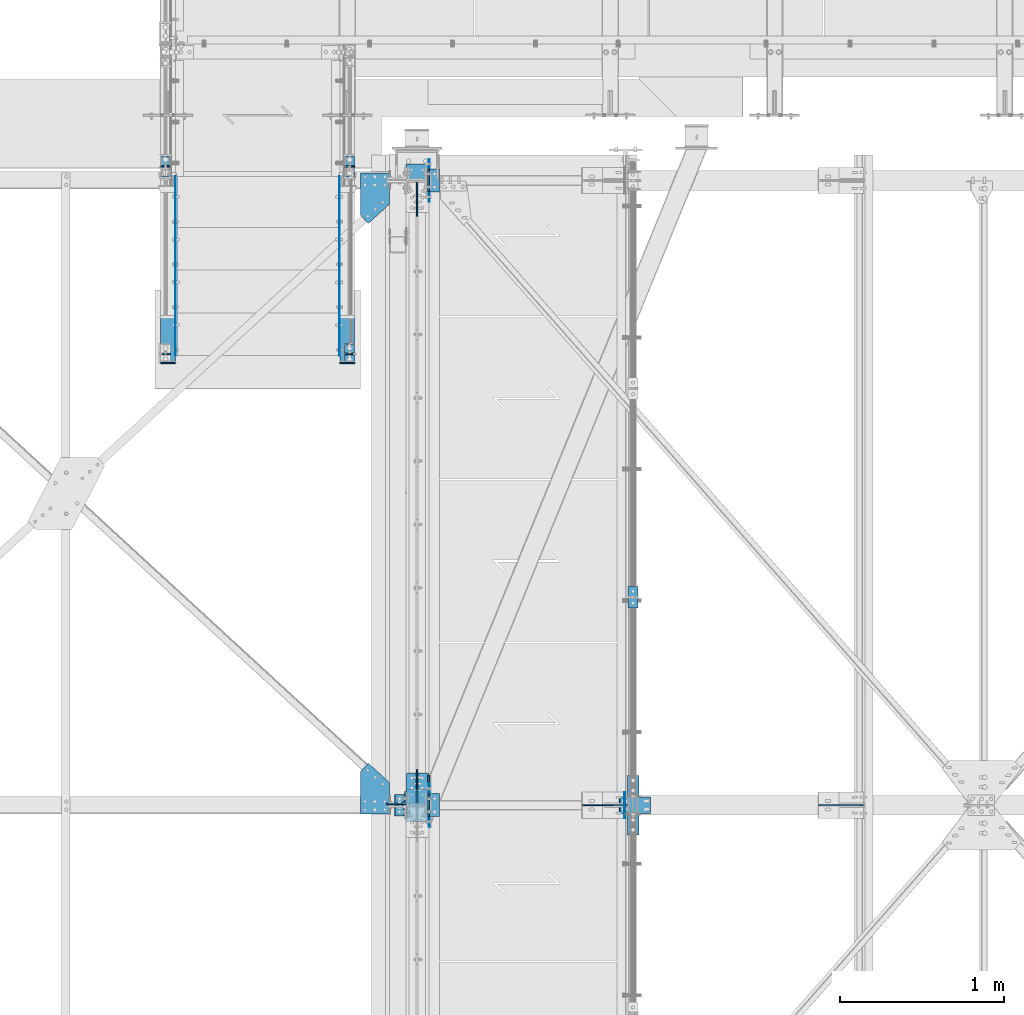
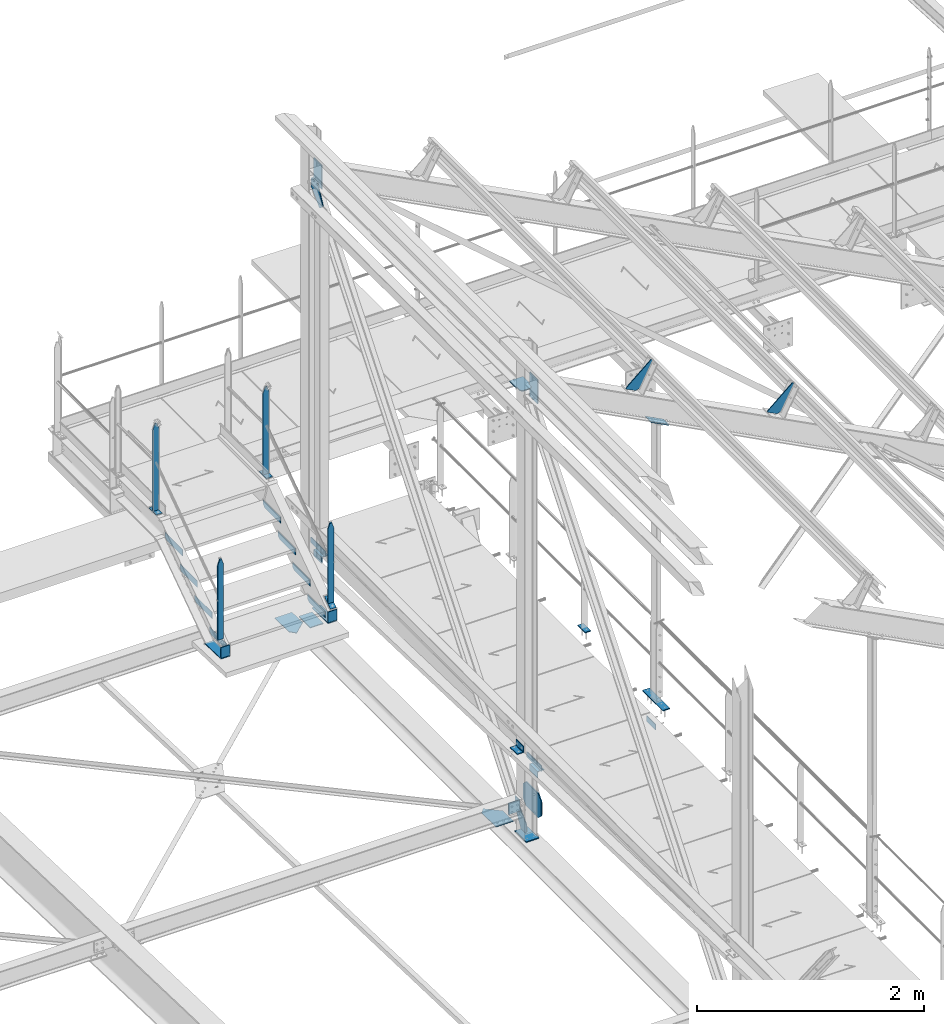
# One storey, part 82 of 496: 38 beams, 3 members, 25 elements without a shape of their own.
"""IFC2X3 building model written with IfcOpenShell, lengths in millimetres."""

from ifc_helpers import new_model, si_unit, frame, frame_2d, origin_with_axes, origin_2d_with_axis, place, context, subcontext, project, spatial, polyline, circle_curve, parameter, trimmed, segment, composite_curve, rectangle, l_section, outline, extrude, clip, halfspace, material, type_object, element, aggregate, save


model = new_model("IFC2X3")

# Units and contexts
model_context = context("Model", 3, precision=1e-05, world=origin_with_axes())
body_context = subcontext(model_context, "Body", "Model", "MODEL_VIEW")
ifc_project = project(units=[si_unit("LENGTHUNIT", "METRE", prefix="MILLI"), si_unit("AREAUNIT", "SQUARE_METRE"), si_unit("VOLUMEUNIT", "CUBIC_METRE"), si_unit("MASSUNIT", "GRAM", prefix="KILO"), si_unit("TIMEUNIT", "SECOND"), si_unit("PLANEANGLEUNIT", "RADIAN"), si_unit("SOLIDANGLEUNIT", "STERADIAN"), si_unit("THERMODYNAMICTEMPERATUREUNIT", "DEGREE_CELSIUS"), si_unit("LUMINOUSINTENSITYUNIT", "LUMEN")], contexts=[model_context])

# Site, building, storey
site_placement = place(None, origin_with_axes())
site = spatial("IfcSite", under=ifc_project, at=site_placement, CompositionType="ELEMENT")
building_placement = place(site_placement, origin_with_axes())
building = spatial("IfcBuilding", under=site, at=building_placement, Name="Undefined", CompositionType="ELEMENT")
storey_placement = place(building_placement, origin_with_axes())
storey = spatial("IfcBuildingStorey", under=building, at=storey_placement, Name="Undefined", CompositionType="ELEMENT", Elevation=0.0)

# Assembly, beams
assembly_1_placement = place(storey_placement, origin_with_axes())
assembly_1 = element("IfcElementAssembly", 1, at=assembly_1_placement, inside=storey, Name="MAIN COURANTE", AssemblyPlace="NOTDEFINED", PredefinedType="NOTDEFINED")
ifc_material = material(Name="Undefined/S235-E24")
beam_type_1 = type_object("IfcBeamType", PredefinedType="NOTDEFINED")
beam_1_placement = place(assembly_1_placement, frame((12269.9936634988, 15350.0038033311, 8915.0), z_axis=(1.0, 0.0, 0.0), x_axis=(0.0, -1.0, 0.0)))
beam_1 = element("IfcBeam", 2, at=beam_1_placement, type_object=beam_type_1, material=ifc_material, context=body_context, shape_type="SweptSolid", body=[
    extrude(rectangle(XDim=10.0, YDim=60.0, at=origin_2d_with_axis()), frame((130.0, 0.0, 0.0), z_axis=(-1.0, 0.0, 0.0), x_axis=(0.0, -1.0, 0.0)), (0.0, 0.0, 1.0), 130.0),
])
beam_2_placement = place(assembly_1_placement, frame((12269.9937887991, 15285.0038033311, 9857.59999847), z_axis=(0.999999999998558, -1.69800000185205e-06, 0.0), x_axis=(0.0, 0.0, -1.0)))
beam_2 = element("IfcBeam", 3, at=beam_2_placement, type_object=beam_type_1, material=ifc_material, Name="MONTANT", context=body_context, shape_type="Clipping", body=[
    clip(clip(extrude(rectangle(XDim=10.0, YDim=60.0, at=origin_2d_with_axis()), frame((937.599998469999, 0.0, 0.0), z_axis=(-1.0, 0.0, 0.0), x_axis=(0.0, -1.0, 0.0)), (0.0, 0.0, 1.0), 937.6), halfspace(frame((-119.999937359999, 4.99999999999818, -30.0), z_axis=(-0.316227766016843, 1.98085072621335e-06, 0.948683298048444), x_axis=(0.948683298050514, 0.0, 0.316227766016838)), False)), halfspace(frame((60.0, 5.0, -30.0), z_axis=(-0.316227469016822, -1.98084886580522e-06, -0.948683397048399), x_axis=(-0.948683298050514, 0.0, 0.316227766016838)), False)),
])

assembly_2_placement = place(storey_placement, origin_with_axes())
assembly_2 = element("IfcElementAssembly", 4, at=assembly_2_placement, inside=storey, Name="MAIN COURANTE", AssemblyPlace="NOTDEFINED", PredefinedType="NOTDEFINED")
beam_3_placement = place(assembly_2_placement, frame((11149.9863365012, 15350.0038033311, 8915.0), z_axis=(-1.0, 0.0, 0.0), x_axis=(0.0, -1.0, 0.0)))
beam_3 = element("IfcBeam", 5, at=beam_3_placement, type_object=beam_type_1, material=ifc_material, context=body_context, shape_type="SweptSolid", body=[
    extrude(rectangle(XDim=10.0, YDim=60.0, at=origin_2d_with_axis()), frame((130.0, 0.0, 0.0), z_axis=(-1.0, 0.0, 0.0), x_axis=(0.0, -1.0, 0.0)), (0.0, 0.0, 1.0), 130.0),
])
beam_4_placement = place(assembly_2_placement, frame((11149.9862112009, 15285.0038033311, 9857.59999847), z_axis=(-0.99999999999782, -2.08799998896818e-06, 0.0), x_axis=(0.0, 0.0, -1.0)))
beam_4 = element("IfcBeam", 6, at=beam_4_placement, type_object=beam_type_1, material=ifc_material, Name="MONTANT", context=body_context, shape_type="Clipping", body=[
    clip(clip(extrude(rectangle(XDim=10.0, YDim=60.0, at=origin_2d_with_axis()), frame((937.599998469999, 0.0, 0.0), z_axis=(-1.0, 0.0, 0.0), x_axis=(0.0, -1.0, 0.0)), (0.0, 0.0, 1.0), 937.6), halfspace(frame((-119.999937359999, -4.99999999999636, -30.0), z_axis=(-0.316227766016837, -1.98085072276202e-06, 0.948683298048446), x_axis=(-6.26399999950979e-06, 0.999999999980381, -3.63797880701241e-15)), False)), halfspace(frame((60.0, -5.0, -30.0), z_axis=(-0.316227469016822, 1.98084886235393e-06, -0.948683397048399), x_axis=(6.26399999950979e-06, 0.999999999980381, -3.63797880701241e-15)), False)),
])
beam_5_placement = place(assembly_2_placement, frame((11149.9862112009, 14144.9998536997, 9085.35366746007), z_axis=(-0.99999999999782, -2.08799998896818e-06, 0.0), x_axis=(0.0, 0.0, -1.0)))
beam_5 = element("IfcBeam", 7, at=beam_5_placement, type_object=beam_type_1, material=ifc_material, Name="MONTANT", context=body_context, shape_type="Clipping", body=[
    clip(clip(clip(clip(extrude(rectangle(XDim=10.0, YDim=60.0, at=origin_2d_with_axis()), frame((863.260305025577, 0.0, 0.0), z_axis=(-1.0, 0.0, 0.0), x_axis=(0.0, -1.0, 0.0)), (0.0, 0.0, 1.0), 870.25), halfspace(frame((-119.999937359999, -4.99999999999636, -30.0), z_axis=(-0.316227766016837, -1.98085072276202e-06, 0.948683298048446), x_axis=(-6.26399999950979e-06, 0.999999999980381, -3.63797880701241e-15)), False)), halfspace(frame((60.0, -5.0, -30.0), z_axis=(-0.316227469016822, 1.98084886235393e-06, -0.948683397048399), x_axis=(6.26399999950979e-06, 0.999999999980381, -3.63797880701241e-15)), False)), halfspace(frame((851.815615457686, -6.43113634479596, -0.000138728501042351), z_axis=(0.822192191679509, -0.569209978778308, -6.66011673277761e-07), x_axis=(0.569209978778308, 0.822192191677987, 1.71673729643302e-06)), False)), halfspace(frame((-7.87605918300687, -11.3765299322586, -0.000149054481880739), z_axis=(0.822192191679509, -0.569209978778308, -6.66011673277761e-07), x_axis=(0.569209978778308, 0.822192191677987, 1.71673729643302e-06)), True)),
])
aggregate(assembly_2, [beam_3, beam_4, beam_5])

# Beam
beam_6_placement = place(assembly_1_placement, frame((12269.9937887991, 14144.9998536997, 9085.35366746007), z_axis=(0.999999999998558, -1.69800000185205e-06, 0.0), x_axis=(0.0, 0.0, -1.0)))
beam_6 = element("IfcBeam", 8, at=beam_6_placement, type_object=beam_type_1, material=ifc_material, Name="MONTANT", context=body_context, shape_type="Clipping", body=[
    clip(clip(clip(clip(extrude(rectangle(XDim=10.0, YDim=60.0, at=origin_2d_with_axis()), frame((863.260305025577, 0.0, 0.0), z_axis=(-1.0, 0.0, 0.0), x_axis=(0.0, -1.0, 0.0)), (0.0, 0.0, 1.0), 870.25), halfspace(frame((-119.999937359999, 4.99999999999818, -30.0), z_axis=(-0.316227766016843, 1.98085072621335e-06, 0.948683298048444), x_axis=(0.948683298050514, 0.0, 0.316227766016838)), False)), halfspace(frame((60.0, 5.0, -30.0), z_axis=(-0.316227469016822, -1.98084886580522e-06, -0.948683397048399), x_axis=(-0.948683298050514, 0.0, 0.316227766016838)), False)), halfspace(frame((851.815615457686, 6.43113634479596, -0.000138728501042351), z_axis=(0.822192191679509, 0.569209978778308, -6.6601167379545e-07), x_axis=(0.0, -2.08799999927579e-06, -0.99999999999782)), False)), halfspace(frame((-7.87605918300687, 11.3765299322586, -0.000149054481880739), z_axis=(0.822192191679509, 0.569209978778308, -6.6601167379545e-07), x_axis=(0.0, -2.08799999927579e-06, -0.99999999999782)), True)),
])

# Assembly, beam
assembly_3_placement = place(storey_placement, origin_with_axes())
assembly_3 = element("IfcElementAssembly", 9, at=assembly_3_placement, inside=storey, Name="MAIN COURANTE", AssemblyPlace="NOTDEFINED", PredefinedType="NOTDEFINED")
beam_7_placement = place(assembly_3_placement, frame((13993.9998916707, 12730.0034471735, 8245.00000008426), z_axis=(-1.0, 0.0, 0.0), x_axis=(0.0, -1.0, 0.0)))
beam_7 = element("IfcBeam", 10, at=beam_7_placement, type_object=beam_type_1, material=ifc_material, context=body_context, shape_type="SweptSolid", body=[
    extrude(rectangle(XDim=10.0, YDim=60.0, at=origin_2d_with_axis()), frame((130.0, 0.0, 0.0), z_axis=(-1.0, 0.0, 0.0), x_axis=(0.0, -1.0, 0.0)), (0.0, 0.0, 1.0), 130.0),
])
aggregate(assembly_3, [beam_7])

# Member
member_type_1 = type_object("IfcMemberType", PredefinedType="NOTDEFINED")
member_1_placement = place(assembly_1_placement, frame((12269.9936634988, 14205.3993570111, 8264.81946439709), z_axis=(1.0, 0.0, 0.0), x_axis=(8.10000000154612e-07, -0.822192191679509, -0.569209978778122)))
member_1 = element("IfcMember", 11, at=member_1_placement, type_object=member_type_1, material=ifc_material, context=body_context, shape_type="SweptSolid", body=[
    extrude(rectangle(XDim=10.0, YDim=60.0, at=origin_2d_with_axis()), frame((130.0, 0.0, 0.0), z_axis=(-1.0, 0.0, 0.0), x_axis=(0.0, -1.0, 0.0)), (0.0, 0.0, 1.0), 130.0),
])

aggregate(assembly_1, [beam_1, beam_2, member_1, beam_6])

# Assembly, beams
assembly_4_placement = place(storey_placement, origin_with_axes())
assembly_4 = element("IfcElementAssembly", 12, at=assembly_4_placement, inside=storey, Name="MARCHE", AssemblyPlace="NOTDEFINED", PredefinedType="NOTDEFINED")
beam_type_2 = type_object("IfcBeamType", PredefinedType="NOTDEFINED")
beam_8_placement = place(assembly_4_placement, frame((11211.4947340707, 15224.9997910501, 8700.0), z_axis=(-1.0, 0.0, 0.0), x_axis=(0.0, 0.0, -1.0)))
beam_8 = element("IfcBeam", 13, at=beam_8_placement, type_object=beam_type_2, material=ifc_material, Name="PLAT MARCHE", context=body_context, shape_type="SweptSolid", body=[
    extrude(outline(polyline([(0.0, 0.0), (50.0, 0.0), (70.0, 30.0), (70.0, 310.0), (0.0, 310.0), (0.0, 0.0)])), frame((0.0, 0.0, -1.5), z_axis=(0.0, 0.0, 1.0), x_axis=(1.0, 0.0, 0.0)), (0.0, 0.0, 1.0), 3.0),
])
beam_9_placement = place(assembly_4_placement, frame((12208.4947340707, 15224.9997910501, 8700.0), z_axis=(-1.0, 0.0, 0.0), x_axis=(0.0, 0.0, -1.0)))
beam_9 = element("IfcBeam", 14, at=beam_9_placement, type_object=beam_type_2, material=ifc_material, Name="PLAT MARCHE", context=body_context, shape_type="SweptSolid", body=[
    extrude(outline(polyline([(0.0, 0.0), (50.0, 0.0), (70.0, 30.0), (70.0, 310.0), (0.0, 310.0), (0.0, 0.0)])), frame((0.0, 0.0, -1.5), z_axis=(0.0, 0.0, 1.0), x_axis=(1.0, 0.0, 0.0)), (0.0, 0.0, 1.0), 3.0),
])
aggregate(assembly_4, [beam_8, beam_9])

assembly_5_placement = place(storey_placement, origin_with_axes())
assembly_5 = element("IfcElementAssembly", 15, at=assembly_5_placement, inside=storey, Name="MARCHE", AssemblyPlace="NOTDEFINED", PredefinedType="NOTDEFINED")
beam_10_placement = place(assembly_5_placement, frame((11211.4947340707, 14964.9997910501, 8520.00000004865), z_axis=(-1.0, 0.0, 0.0), x_axis=(0.0, 0.0, -1.0)))
beam_10 = element("IfcBeam", 16, at=beam_10_placement, type_object=beam_type_2, material=ifc_material, Name="PLAT MARCHE", context=body_context, shape_type="SweptSolid", body=[
    extrude(outline(polyline([(0.0, 0.0), (50.0, 0.0), (70.0, 30.0), (70.0, 310.0), (0.0, 310.0), (0.0, 0.0)])), frame((0.0, 0.0, -1.5), z_axis=(0.0, 0.0, 1.0), x_axis=(1.0, 0.0, 0.0)), (0.0, 0.0, 1.0), 3.0),
])
beam_11_placement = place(assembly_5_placement, frame((12208.4947340707, 14964.9997910501, 8520.00000004865), z_axis=(-1.0, 0.0, 0.0), x_axis=(0.0, 0.0, -1.0)))
beam_11 = element("IfcBeam", 17, at=beam_11_placement, type_object=beam_type_2, material=ifc_material, Name="PLAT MARCHE", context=body_context, shape_type="SweptSolid", body=[
    extrude(outline(polyline([(0.0, 0.0), (50.0, 0.0), (70.0, 30.0), (70.0, 310.0), (0.0, 310.0), (0.0, 0.0)])), frame((0.0, 0.0, -1.5), z_axis=(0.0, 0.0, 1.0), x_axis=(1.0, 0.0, 0.0)), (0.0, 0.0, 1.0), 3.0),
])
aggregate(assembly_5, [beam_10, beam_11])

assembly_6_placement = place(storey_placement, origin_with_axes())
assembly_6 = element("IfcElementAssembly", 18, at=assembly_6_placement, inside=storey, Name="MARCHE", AssemblyPlace="NOTDEFINED", PredefinedType="NOTDEFINED")
beam_12_placement = place(assembly_6_placement, frame((11211.4947340707, 14704.9997910501, 8340.00000007297), z_axis=(-1.0, 0.0, 0.0), x_axis=(0.0, 0.0, -1.0)))
beam_12 = element("IfcBeam", 19, at=beam_12_placement, type_object=beam_type_2, material=ifc_material, Name="PLAT MARCHE", context=body_context, shape_type="SweptSolid", body=[
    extrude(outline(polyline([(0.0, 0.0), (50.0, 0.0), (70.0, 30.0), (70.0, 310.0), (0.0, 310.0), (0.0, 0.0)])), frame((0.0, 0.0, -1.5), z_axis=(0.0, 0.0, 1.0), x_axis=(1.0, 0.0, 0.0)), (0.0, 0.0, 1.0), 3.0),
])
beam_13_placement = place(assembly_6_placement, frame((12208.4947340707, 14704.9997910501, 8340.00000007297), z_axis=(-1.0, 0.0, 0.0), x_axis=(0.0, 0.0, -1.0)))
beam_13 = element("IfcBeam", 20, at=beam_13_placement, type_object=beam_type_2, material=ifc_material, Name="PLAT MARCHE", context=body_context, shape_type="SweptSolid", body=[
    extrude(outline(polyline([(0.0, 0.0), (50.0, 0.0), (70.0, 30.0), (70.0, 310.0), (0.0, 310.0), (0.0, 0.0)])), frame((0.0, 0.0, -1.5), z_axis=(0.0, 0.0, 1.0), x_axis=(1.0, 0.0, 0.0)), (0.0, 0.0, 1.0), 3.0),
])
aggregate(assembly_6, [beam_12, beam_13])

assembly_7_placement = place(storey_placement, origin_with_axes())
assembly_7 = element("IfcElementAssembly", 21, at=assembly_7_placement, inside=storey, Name="MARCHE", AssemblyPlace="NOTDEFINED", PredefinedType="NOTDEFINED")
beam_14_placement = place(assembly_7_placement, frame((11211.4947340707, 14444.9997910501, 8160.0000000973), z_axis=(-1.0, 0.0, 0.0), x_axis=(0.0, 0.0, -1.0)))
beam_14 = element("IfcBeam", 22, at=beam_14_placement, type_object=beam_type_2, material=ifc_material, Name="PLAT MARCHE", context=body_context, shape_type="SweptSolid", body=[
    extrude(outline(polyline([(0.0, 0.0), (50.0, 0.0), (70.0, 30.0), (70.0, 310.0), (0.0, 310.0), (0.0, 0.0)])), frame((0.0, 0.0, -1.5), z_axis=(0.0, 0.0, 1.0), x_axis=(1.0, 0.0, 0.0)), (0.0, 0.0, 1.0), 3.0),
])
beam_15_placement = place(assembly_7_placement, frame((12208.4947340707, 14444.9997910501, 8160.0000000973), z_axis=(-1.0, 0.0, 0.0), x_axis=(0.0, 0.0, -1.0)))
beam_15 = element("IfcBeam", 23, at=beam_15_placement, type_object=beam_type_2, material=ifc_material, Name="PLAT MARCHE", context=body_context, shape_type="SweptSolid", body=[
    extrude(outline(polyline([(0.0, 0.0), (50.0, 0.0), (70.0, 30.0), (70.0, 310.0), (0.0, 310.0), (0.0, 0.0)])), frame((0.0, 0.0, -1.5), z_axis=(0.0, 0.0, 1.0), x_axis=(1.0, 0.0, 0.0)), (0.0, 0.0, 1.0), 3.0),
])
aggregate(assembly_7, [beam_14, beam_15])

assembly_8_placement = place(storey_placement, origin_with_axes())
assembly_8 = element("IfcElementAssembly", 24, at=assembly_8_placement, inside=storey, AssemblyPlace="NOTDEFINED", PredefinedType="NOTDEFINED")
beam_type_3 = type_object("IfcBeamType", PredefinedType="NOTDEFINED")
beam_16_placement = place(assembly_8_placement, frame((12254.9938754006, 14370.1040990241, 8052.62545207049), z_axis=(1.0, 0.0, 0.0), x_axis=(0.0, -0.999506556345276, 0.031410887010852)))
beam_16 = element("IfcBeam", 25, at=beam_16_placement, type_object=beam_type_3, material=ifc_material, Name="PLAT", context=body_context, shape_type="SweptSolid", body=[
    extrude(rectangle(XDim=8.0, YDim=90.0, at=origin_2d_with_axis()), frame((285.370765885938, 0.0, 0.0), z_axis=(-1.0, 0.0, 0.0), x_axis=(0.0, -1.0, 0.0)), (0.0, 0.0, 1.0), 285.37),
])
beam_17_placement = place(assembly_8_placement, frame((12254.9938754006, 14088.9997910799, 8180.92307703739), z_axis=(1.0, 0.0, 0.0), x_axis=(0.0, 0.0, -1.0)))
beam_17 = element("IfcBeam", 26, at=beam_17_placement, type_object=beam_type_3, material=ifc_material, Name="PLAT", context=body_context, shape_type="SweptSolid", body=[
    extrude(rectangle(XDim=8.0, YDim=90.0, at=origin_2d_with_axis()), frame((114.997260996663, 0.0, 0.0), z_axis=(-1.0, 0.0, 0.0), x_axis=(0.0, -1.0, 0.0)), (0.0, 0.0, 1.0), 115.0),
])
aggregate(assembly_8, [beam_16, beam_17])

assembly_9_placement = place(storey_placement, origin_with_axes())
assembly_9 = element("IfcElementAssembly", 27, at=assembly_9_placement, inside=storey, AssemblyPlace="NOTDEFINED", PredefinedType="NOTDEFINED")
beam_18_placement = place(assembly_9_placement, frame((11165.0061245995, 14370.1040990241, 8052.62545207049), z_axis=(-1.0, 0.0, 0.0), x_axis=(0.0, -0.999506556345276, 0.031410887010852)))
beam_18 = element("IfcBeam", 28, at=beam_18_placement, type_object=beam_type_3, material=ifc_material, Name="PLAT", context=body_context, shape_type="SweptSolid", body=[
    extrude(rectangle(XDim=8.0, YDim=90.0, at=origin_2d_with_axis()), frame((285.370765885938, 0.0, 0.0), z_axis=(-1.0, 0.0, 0.0), x_axis=(0.0, -1.0, 0.0)), (0.0, 0.0, 1.0), 285.37),
])
beam_19_placement = place(assembly_9_placement, frame((11165.0061245995, 14088.9997910799, 8180.92307703739), z_axis=(-1.0, 0.0, 0.0), x_axis=(0.0, 0.0, -1.0)))
beam_19 = element("IfcBeam", 29, at=beam_19_placement, type_object=beam_type_3, material=ifc_material, Name="PLAT", context=body_context, shape_type="SweptSolid", body=[
    extrude(rectangle(XDim=8.0, YDim=90.0, at=origin_2d_with_axis()), frame((114.997260996663, 0.0, 0.0), z_axis=(-1.0, 0.0, 0.0), x_axis=(0.0, -1.0, 0.0)), (0.0, 0.0, 1.0), 115.0),
])
aggregate(assembly_9, [beam_18, beam_19])

# Assembly, beam
assembly_10_placement = place(storey_placement, origin_with_axes())
assembly_10 = element("IfcElementAssembly", 30, at=assembly_10_placement, inside=storey, AssemblyPlace="NOTDEFINED", PredefinedType="NOTDEFINED")
beam_type_4 = type_object("IfcBeamType", PredefinedType="NOTDEFINED")
beam_20_placement = place(assembly_10_placement, frame((12781.5082291039, 15130.0, 7915.0), z_axis=(1.0, 0.0, 0.0), x_axis=(0.0, 1.0, 0.0)))
beam_20 = element("IfcBeam", 31, at=beam_20_placement, type_object=beam_type_4, material=ifc_material, context=body_context, shape_type="SweptSolid", body=[
    extrude(l_section(Depth=70.0, Width=70.0, Thickness=7.0, FilletRadius=9.0, EdgeRadius=4.5, at=origin_2d_with_axis()), frame((140.0, 0.0, 0.0), z_axis=(-1.0, 0.0, 0.0), x_axis=(0.0, -1.0, 0.0)), (0.0, 0.0, 1.0), 140.0),
])
aggregate(assembly_10, [beam_20])

assembly_11_placement = place(storey_placement, origin_with_axes())
assembly_11 = element("IfcElementAssembly", 32, at=assembly_11_placement, inside=storey, AssemblyPlace="NOTDEFINED", PredefinedType="NOTDEFINED")
beam_21_placement = place(assembly_11_placement, frame((12781.5082291039, 11330.0, 7915.0), z_axis=(1.0, 0.0, 0.0), x_axis=(0.0, 1.0, 0.0)))
beam_21 = element("IfcBeam", 33, at=beam_21_placement, type_object=beam_type_4, material=ifc_material, context=body_context, shape_type="SweptSolid", body=[
    extrude(l_section(Depth=70.0, Width=70.0, Thickness=7.0, FilletRadius=9.0, EdgeRadius=4.5, at=origin_2d_with_axis()), frame((140.0, 0.0, 0.0), z_axis=(-1.0, 0.0, 0.0), x_axis=(0.0, -1.0, 0.0)), (0.0, 0.0, 1.0), 140.0),
])
aggregate(assembly_11, [beam_21])

assembly_12_placement = place(storey_placement, origin_with_axes())
assembly_12 = element("IfcElementAssembly", 34, at=assembly_12_placement, inside=storey, AssemblyPlace="NOTDEFINED", PredefinedType="NOTDEFINED")
beam_22_placement = place(assembly_12_placement, frame((12578.5000000376, 11464.8129140242, 8229.98135168843), z_axis=(0.0, 0.0314135610096692, 0.999506472307554), x_axis=(0.0, -0.999506472307554, 0.031413561009669)))
beam_22 = element("IfcBeam", 35, at=beam_22_placement, type_object=beam_type_4, material=ifc_material, context=body_context, shape_type="SweptSolid", body=[
    extrude(l_section(Depth=70.0, Width=70.0, Thickness=7.0, FilletRadius=9.0, EdgeRadius=4.5, at=origin_2d_with_axis()), frame((130.004127993981, 0.0, 9.02084851220212e-16), z_axis=(-1.0, 0.0, 0.0), x_axis=(0.0, -1.0, 0.0)), (0.0, 0.0, 1.0), 130.0),
])
aggregate(assembly_12, [beam_22])

assembly_13_placement = place(storey_placement, origin_with_axes())
assembly_13 = element("IfcElementAssembly", 36, at=assembly_13_placement, inside=storey, Name="SHED", AssemblyPlace="NOTDEFINED", PredefinedType="NOTDEFINED")
beam_type_5 = type_object("IfcBeamType", PredefinedType="NOTDEFINED")
beam_23_placement = place(assembly_13_placement, frame((15395.0613651869, 11400.0, 11158.7378432617), z_axis=(0.0, -1.0, 0.0), x_axis=(-0.886081824994261, -1.3000000762986e-08, 0.46352885499701)))
beam_23 = element("IfcBeam", 37, at=beam_23_placement, type_object=beam_type_5, material=ifc_material, context=body_context, shape_type="SweptSolid", body=[
    extrude(outline(polyline([(0.0, 0.0), (20.0, 0.0), (140.000030519084, 299.999999999567), (140.000030519153, 319.999999999545), (30.0000147075953, 319.999999999634), (0.0, 290.0), (0.0, 0.0)])), frame((0.0, 0.0, -4.0), z_axis=(0.0, 0.0, 1.0), x_axis=(1.0, 0.0, 0.0)), (0.0, 0.0, 1.0), 8.0),
])
aggregate(assembly_13, [beam_23])

assembly_14_placement = place(storey_placement, origin_with_axes())
assembly_14 = element("IfcElementAssembly", 38, at=assembly_14_placement, inside=storey, Name="SHED", AssemblyPlace="NOTDEFINED", PredefinedType="NOTDEFINED")
beam_24_placement = place(assembly_14_placement, frame((13957.7613225854, 11400.0, 11910.6201334583), z_axis=(0.0, -1.0, 0.0), x_axis=(-0.886081824994261, -1.3000000762986e-08, 0.46352885499701)))
beam_24 = element("IfcBeam", 39, at=beam_24_placement, type_object=beam_type_5, material=ifc_material, context=body_context, shape_type="SweptSolid", body=[
    extrude(outline(polyline([(0.0, 0.0), (20.0, 0.0), (140.000030519084, 299.999999999567), (140.000030519153, 319.999999999545), (30.0000147075953, 319.999999999634), (0.0, 290.0), (0.0, 0.0)])), frame((0.0, 0.0, -4.0), z_axis=(0.0, 0.0, 1.0), x_axis=(1.0, 0.0, 0.0)), (0.0, 0.0, 1.0), 8.0),
])
aggregate(assembly_14, [beam_24])

assembly_15_placement = place(storey_placement, origin_with_axes())
assembly_15 = element("IfcElementAssembly", 40, at=assembly_15_placement, inside=storey, AssemblyPlace="NOTDEFINED", PredefinedType="NOTDEFINED")
beam_type_6 = type_object("IfcBeamType", PredefinedType="NOTDEFINED")
beam_25_placement = place(assembly_15_placement, frame((12751.5082288882, 11266.0627902337, 7721.69334954953), z_axis=(1.0, 0.0, 0.0), x_axis=(0.0, 0.0, -1.0)))
beam_25 = element("IfcBeam", 41, at=beam_25_placement, type_object=beam_type_6, material=ifc_material, context=body_context, shape_type="Clipping", body=[
    clip(clip(clip(clip(extrude(outline(polyline([(0.0, 0.0), (260.0, -1.72803993336856e-10), (260.0, 316.727111816233), (-1.43547367770225e-07, 316.727111816233), (0.0, 0.0)])), frame((0.0, 0.0, -5.0), z_axis=(0.0, 0.0, 1.0), x_axis=(1.0, 0.0, 0.0)), (0.0, 0.0, 1.0), 10.0), halfspace(frame((550.000000220164, -499.999999994781, -5.0), z_axis=(-0.707106781186457, -0.707106781186639, 0.0), x_axis=(-0.707106781479439, 0.707106780893656, 2.92893673836224e-10)), False)), halfspace(frame((-766.727111662242, -499.999999993823, -5.0), z_axis=(-0.707106781479439, 0.707106780893656, 2.92893673836224e-10), x_axis=(0.707106780893656, 0.707106781479439, 2.92893673836224e-10)), False)), halfspace(frame((1026.72711213867, -499.999999995129, 5.0), z_axis=(0.707106780893656, 0.707106781479439, 2.92893673836224e-10), x_axis=(-0.707106781479439, 0.707106780893656, 2.92893673836224e-10)), False)), halfspace(frame((-289.999999924667, -499.99999999417, 5.0), z_axis=(0.707106781479439, -0.707106780893656, 0.0), x_axis=(0.707106780893656, 0.707106781479439, 2.92893673836224e-10)), False)),
])
aggregate(assembly_15, [beam_25])

assembly_16_placement = place(storey_placement, origin_with_axes())
assembly_16 = element("IfcElementAssembly", 42, at=assembly_16_placement, inside=storey, AssemblyPlace="NOTDEFINED", PredefinedType="NOTDEFINED")
beam_type_7 = type_object("IfcBeamType", PredefinedType="NOTDEFINED")
beam_26_placement = place(assembly_16_placement, frame((12383.2639945892, 11655.9483940289, 7480.59839222682), z_axis=(0.0, -0.031410887010906, -0.999506556345274), x_axis=(0.736014469807791, -0.6766317528233, 0.021264319994449)))
beam_26 = element("IfcBeam", 43, at=beam_26_placement, type_object=beam_type_7, material=ifc_material, context=body_context, shape_type="SweptSolid", body=[
    extrude(outline(polyline([(0.0, 0.0), (176.947631836567, 5.82076609134674e-10), (305.251708985372, 139.495483399041), (174.518157960065, 259.740600585897), (-7.90371359471465e-08, 70.000007629249), (0.0, 0.0)])), frame((0.0, 0.0, -3.0), z_axis=(0.0, 0.0, 1.0), x_axis=(1.0, 0.0, 0.0)), (0.0, 0.0, 1.0), 6.0),
])
aggregate(assembly_16, [beam_26])

assembly_17_placement = place(storey_placement, origin_with_axes())
assembly_17 = element("IfcElementAssembly", 44, at=assembly_17_placement, inside=storey, AssemblyPlace="NOTDEFINED", PredefinedType="NOTDEFINED")
beam_27_placement = place(assembly_17_placement, frame((12383.2639945894, 14937.5769481269, 7377.46755199249), z_axis=(0.0, 0.031410887010906, 0.999506556345274), x_axis=(0.736014469792141, 0.67663175280891, -0.0212643209939943)))
beam_27 = element("IfcBeam", 45, at=beam_27_placement, type_object=beam_type_7, material=ifc_material, context=body_context, shape_type="SweptSolid", body=[
    extrude(outline(polyline([(0.0, 0.0), (176.947631836567, 5.82076609134674e-10), (305.251708985372, 139.495483399041), (174.518157960065, 259.740600585897), (-7.90371359471465e-08, 70.000007629249), (0.0, 0.0)])), frame((0.0, 0.0, -3.0), z_axis=(0.0, 0.0, 1.0), x_axis=(1.0, 0.0, 0.0)), (0.0, 0.0, 1.0), 6.0),
])
aggregate(assembly_17, [beam_27])

assembly_18_placement = place(storey_placement, origin_with_axes())
assembly_18 = element("IfcElementAssembly", 46, at=assembly_18_placement, inside=storey, Name="MONTANT", AssemblyPlace="NOTDEFINED", PredefinedType="NOTDEFINED")
beam_type_8 = type_object("IfcBeamType", PredefinedType="NOTDEFINED")
beam_28_placement = place(assembly_18_placement, frame((12680.0, 15300.0, 7255.0), z_axis=(1.0, 0.0, 0.0), x_axis=(0.0, -1.0, 0.0)))
beam_28 = element("IfcBeam", 47, at=beam_28_placement, type_object=beam_type_8, material=ifc_material, context=body_context, shape_type="SweptSolid", body=[
    extrude(rectangle(XDim=10.0, YDim=133.0, at=origin_2d_with_axis()), frame((200.0, 0.0, 0.0), z_axis=(-1.0, 0.0, 0.0), x_axis=(0.0, -1.0, 0.0)), (0.0, 0.0, 1.0), 200.0),
])

assembly_19_placement = place(storey_placement, origin_with_axes())
assembly_19 = element("IfcElementAssembly", 48, at=assembly_19_placement, inside=storey, Name="MONTANT", AssemblyPlace="NOTDEFINED", PredefinedType="NOTDEFINED")
beam_29_placement = place(assembly_19_placement, frame((12680.0, 11500.0, 7255.0), z_axis=(1.0, 0.0, 0.0), x_axis=(0.0, -1.0, 0.0)))
beam_29 = element("IfcBeam", 49, at=beam_29_placement, type_object=beam_type_8, material=ifc_material, context=body_context, shape_type="SweptSolid", body=[
    extrude(rectangle(XDim=10.0, YDim=133.0, at=origin_2d_with_axis()), frame((200.0, 0.0, 0.0), z_axis=(-1.0, 0.0, 0.0), x_axis=(0.0, -1.0, 0.0)), (0.0, 0.0, 1.0), 200.0),
])

# Assembly, member
assembly_20_placement = place(storey_placement, origin_with_axes())
assembly_20 = element("IfcElementAssembly", 50, at=assembly_20_placement, inside=storey, AssemblyPlace="NOTDEFINED", PredefinedType="NOTDEFINED")
member_type_2 = type_object("IfcMemberType", PredefinedType="NOTDEFINED")
member_2_placement = place(assembly_20_placement, frame((13911.9348604257, 11400.0000000133, 11285.668922065), z_axis=(0.0, -1.0, 0.0), x_axis=(0.886081856298361, 3.500000375794e-08, -0.463528795156082)))
member_2 = element("IfcMember", 51, at=member_2_placement, type_object=member_type_2, material=ifc_material, context=body_context, shape_type="SweptSolid", body=[
    extrude(rectangle(XDim=10.0, YDim=100.0, at=origin_2d_with_axis()), frame((210.000000000491, 0.0, 1.81898940354586e-12), z_axis=(-1.0, 0.0, 0.0), x_axis=(0.0, -1.0, 0.0)), (0.0, 0.0, 1.0), 210.0),
])

# Assembly, beam
assembly_21_placement = place(storey_placement, origin_with_axes())
assembly_21 = element("IfcElementAssembly", 52, at=assembly_21_placement, inside=storey, AssemblyPlace="NOTDEFINED", PredefinedType="NOTDEFINED")
beam_type_9 = type_object("IfcBeamType", PredefinedType="NOTDEFINED")
beam_30_placement = place(assembly_21_placement, frame((13942.9998855295, 11320.0, 7985.0), z_axis=(-1.0, 0.0, 0.0), x_axis=(0.0, 0.0, 1.0)))
beam_30 = element("IfcBeam", 53, at=beam_30_placement, type_object=beam_type_9, material=ifc_material, context=body_context, shape_type="SweptSolid", body=[
    extrude(outline(polyline([(0.0, 0.0), (60.0, 0.0), (60.0, 159.999984741211), (0.0, 159.999984741211), (0.0, 0.0)])), frame((0.0, 0.0, -3.0), z_axis=(0.0, 0.0, 1.0), x_axis=(1.0, 0.0, 0.0)), (0.0, 0.0, 1.0), 6.0),
])

assembly_22_placement = place(storey_placement, origin_with_axes())
assembly_22 = element("IfcElementAssembly", 54, at=assembly_22_placement, inside=storey, AssemblyPlace="NOTDEFINED", PredefinedType="NOTDEFINED")
beam_31_placement = place(assembly_22_placement, frame((12755.0001144705, 15070.0, 7985.0), z_axis=(-1.0, 0.0, 0.0), x_axis=(0.0, 0.0, 1.0)))
beam_31 = element("IfcBeam", 55, at=beam_31_placement, type_object=beam_type_9, material=ifc_material, context=body_context, shape_type="SweptSolid", body=[
    extrude(outline(polyline([(0.0, 0.0), (60.0, 0.0), (60.0, 260.0), (0.0, 260.0), (0.0, 0.0)])), frame((0.0, 0.0, -3.0), z_axis=(0.0, 0.0, 1.0), x_axis=(1.0, 0.0, 0.0)), (0.0, 0.0, 1.0), 6.0),
])
aggregate(assembly_22, [beam_31])

# Beam
beam_32_placement = place(assembly_21_placement, frame((12755.0001144705, 11270.0, 7985.0), z_axis=(-1.0, 0.0, 0.0), x_axis=(0.0, 0.0, 1.0)))
beam_32 = element("IfcBeam", 56, at=beam_32_placement, type_object=beam_type_9, material=ifc_material, context=body_context, shape_type="SweptSolid", body=[
    extrude(outline(polyline([(0.0, 0.0), (60.0, 0.0), (60.0, 260.0), (0.0, 260.0), (0.0, 0.0)])), frame((0.0, 0.0, -3.0), z_axis=(0.0, 0.0, 1.0), x_axis=(1.0, 0.0, 0.0)), (0.0, 0.0, 1.0), 6.0),
])

aggregate(assembly_21, [beam_30, beam_32])

beam_type_10 = type_object("IfcBeamType", PredefinedType="NOTDEFINED")
beam_33_placement = place(assembly_20_placement, frame((13993.9998855295, 11580.0001061627, 8245.00000367738), z_axis=(1.0, 0.0, 0.0), x_axis=(0.0, -1.0, 0.0)))
beam_33 = element("IfcBeam", 57, at=beam_33_placement, type_object=beam_type_10, material=ifc_material, context=body_context, shape_type="SweptSolid", body=[
    extrude(rectangle(XDim=10.0, YDim=70.0, at=origin_2d_with_axis()), frame((360.000000000004, 0.0, 0.0), z_axis=(-1.0, 0.0, 0.0), x_axis=(0.0, -1.0, 0.0)), (0.0, 0.0, 1.0), 360.0),
])

aggregate(assembly_20, [member_2, beam_33])

# Assembly, beam
assembly_23_placement = place(storey_placement, origin_with_axes())
assembly_23 = element("IfcElementAssembly", 58, at=assembly_23_placement, inside=storey, Name="TRAVERSE SHED", AssemblyPlace="NOTDEFINED", PredefinedType="NOTDEFINED")
beam_type_11 = type_object("IfcBeamType", PredefinedType="NOTDEFINED")
beam_34_placement = place(assembly_23_placement, frame((12751.5, 15200.0, 12161.0697488335), z_axis=(0.0, -1.0, 0.0), x_axis=(0.0, 0.0, -1.0)))
beam_34 = element("IfcBeam", 59, at=beam_34_placement, type_object=beam_type_11, material=ifc_material, context=body_context, shape_type="SweptSolid", body=[
    extrude(rectangle(XDim=10.0, YDim=140.0, at=origin_2d_with_axis()), frame((259.795359497664, 0.0, 0.0), z_axis=(-1.0, 0.0, 0.0), x_axis=(0.0, -1.0, 0.0)), (0.0, 0.0, 1.0), 259.8),
])
aggregate(assembly_23, [beam_34])

assembly_24_placement = place(storey_placement, origin_with_axes())
assembly_24 = element("IfcElementAssembly", 60, at=assembly_24_placement, inside=storey, Name="TRAVERSE SHED", AssemblyPlace="NOTDEFINED", PredefinedType="NOTDEFINED")
beam_35_placement = place(assembly_24_placement, frame((12751.5, 11400.0, 12161.0697488335), z_axis=(0.0, -1.0, 0.0), x_axis=(0.0, 0.0, -1.0)))
beam_35 = element("IfcBeam", 61, at=beam_35_placement, type_object=beam_type_11, material=ifc_material, context=body_context, shape_type="SweptSolid", body=[
    extrude(rectangle(XDim=10.0, YDim=140.0, at=origin_2d_with_axis()), frame((259.795359497664, 0.0, 0.0), z_axis=(-1.0, 0.0, 0.0), x_axis=(0.0, -1.0, 0.0)), (0.0, 0.0, 1.0), 259.8),
])
aggregate(assembly_24, [beam_35])

# Assembly, member
assembly_25_placement = place(storey_placement, origin_with_axes())
assembly_25 = element("IfcElementAssembly", 62, at=assembly_25_placement, inside=storey, AssemblyPlace="NOTDEFINED", PredefinedType="NOTDEFINED")
member_type_3 = type_object("IfcMemberType", PredefinedType="NOTDEFINED")
member_3_placement = place(assembly_25_placement, frame((12553.5000000005, 11444.86430251, 7650.30906880561), z_axis=(-1.0, 0.0, 0.0), x_axis=(0.0, -0.031410887010906, -0.999506556345274)))
member_3 = element("IfcMember", 63, at=member_3_placement, type_object=member_type_3, material=ifc_material, context=body_context, shape_type="SweptSolid", body=[
    extrude(l_section(Depth=120.0, Width=80.0, Thickness=10.0, FilletRadius=11.0, EdgeRadius=5.5, at=origin_2d_with_axis()), frame((120.0, 0.0, 0.0), z_axis=(-1.0, 0.0, 0.0), x_axis=(0.0, -1.0, 0.0)), (0.0, 0.0, 1.0), 120.0),
])
aggregate(assembly_25, [member_3])

# Beam
beam_type_12 = type_object("IfcBeamType", PredefinedType="NOTDEFINED")
beam_36_placement = place(assembly_19_placement, frame((12680.0, 11500.0, 7260.0), z_axis=(-1.0, 0.0, 0.0), x_axis=(0.0, -1.0, 0.0)))
beam_36 = element("IfcBeam", 64, at=beam_36_placement, type_object=beam_type_12, material=ifc_material, context=body_context, shape_type="SweptSolid", body=[
    extrude(outline(polyline([(0.0, 0.0), (77.25, 0.0), (97.25, 20.0), (97.25, 100.0), (-55.1922302246094, 249.837203979492), (-117.850288391113, 200.098205566406), (0.0, 0.0)])), frame((0.0, 0.0, -4.0), z_axis=(0.0, 0.0, 1.0), x_axis=(1.0, 0.0, 0.0)), (0.0, 0.0, 1.0), 8.0),
])

beam_type_13 = type_object("IfcBeamType", PredefinedType="NOTDEFINED")
beam_37_placement = place(assembly_19_placement, frame((12613.5, 11595.0, 12032.0), z_axis=(0.0, 0.0, 1.0), x_axis=(0.0, -1.0, 0.0)))
beam_37 = element("IfcBeam", 65, at=beam_37_placement, type_object=beam_type_13, material=ifc_material, Name="PLAT", context=body_context, shape_type="SweptSolid", body=[
    extrude(outline(composite_curve([segment(trimmed(circle_curve(frame_2d((10.0, 10.0), x_axis=(-1.0, 0.0)), 10.0), [parameter(0.0)], [parameter(1.5707963267949)], True, "PARAMETER"), True, "CONTINUOUS"), segment(polyline([(9.99999999997453, 6.91215973347425e-11), (124.5, 0.0), (124.5, 9.0), (172.25, 9.0), (192.25, 29.0), (192.25, 104.0), (172.25, 124.0), (124.0, 124.0), (124.0, 140.0), (10.0, 140.0)]), True, "CONTINUOUS"), segment(trimmed(circle_curve(frame_2d((10.0, 130.0), x_axis=(0.0, 1.0)), 10.0), [parameter(0.0)], [parameter(1.5707963267949)], True, "PARAMETER"), True, "CONTINUOUS"), segment(polyline([(0.0, 130.0), (-1.81898940354586e-10, 10.0000000000073)]), True, "CONTINUOUS")], self_intersect=True)), frame((0.0, 0.0, -5.0), z_axis=(0.0, 0.0, 1.0), x_axis=(1.0, 0.0, 0.0)), (0.0, 0.0, 1.0), 10.0),
])

aggregate(assembly_19, [beam_36, beam_37, beam_29])

beam_type_14 = type_object("IfcBeamType", PredefinedType="NOTDEFINED")
beam_38_placement = place(assembly_18_placement, frame((12680.0, 15080.0, 12027.0), z_axis=(-1.0, 0.0, 0.0), x_axis=(0.0, 1.0, 0.0)))
beam_38 = element("IfcBeam", 66, at=beam_38_placement, type_object=beam_type_14, material=ifc_material, context=body_context, shape_type="SweptSolid", body=[
    extrude(outline(polyline([(0.0, 0.0), (97.2469253540039, 0.0), (117.246925354004, 20.0), (117.246925354004, 100.0), (-35.1922302246094, 249.837203979492), (-97.8502807617188, 200.098205566406), (0.0, 0.0)])), frame((0.0, 0.0, -4.0), z_axis=(0.0, 0.0, 1.0), x_axis=(1.0, 0.0, 0.0)), (0.0, 0.0, 1.0), 8.0),
])

aggregate(assembly_18, [beam_38, beam_28])

save(model, "model.ifc")
